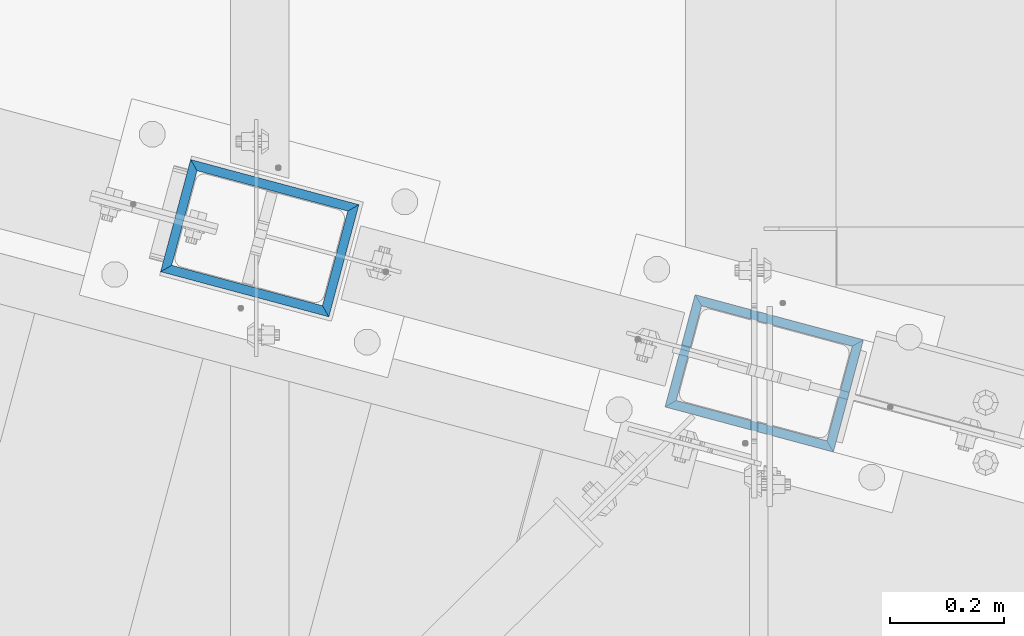
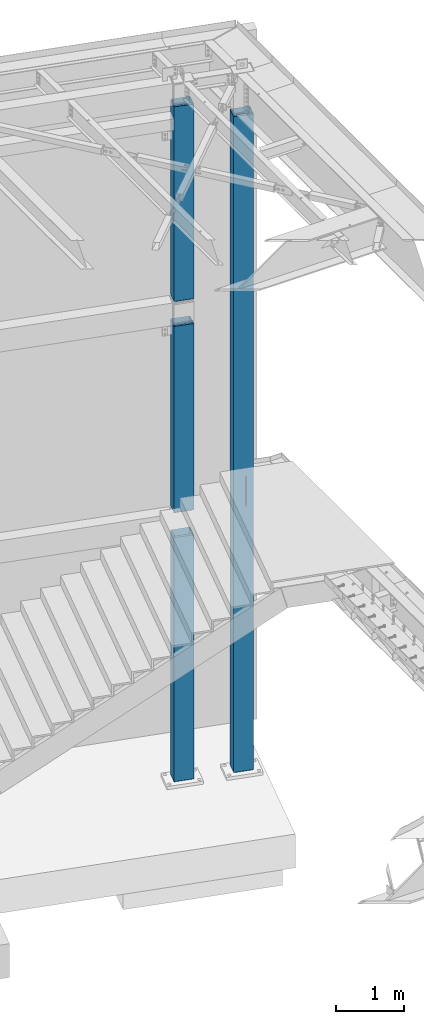
# One storey, part 917 of 1763: 4 columns, 2 elements without a shape of their own.
"""IFC2X3 building model written with IfcOpenShell, lengths in millimetres."""

from ifc_helpers import new_model, si_unit, frame, origin_with_axes, place, context, subcontext, project, spatial, faceted_brep, material, type_object, element, aggregate, save


model = new_model("IFC2X3")

# Units and contexts
model_context = context("Model", 3, precision=1e-05, world=origin_with_axes())
body_context = subcontext(model_context, "Body", "Model", "MODEL_VIEW")
ifc_project = project(units=[si_unit("LENGTHUNIT", "METRE", prefix="MILLI"), si_unit("AREAUNIT", "SQUARE_METRE"), si_unit("VOLUMEUNIT", "CUBIC_METRE"), si_unit("MASSUNIT", "GRAM", prefix="KILO"), si_unit("TIMEUNIT", "SECOND"), si_unit("PLANEANGLEUNIT", "RADIAN"), si_unit("SOLIDANGLEUNIT", "STERADIAN"), si_unit("THERMODYNAMICTEMPERATUREUNIT", "DEGREE_CELSIUS"), si_unit("LUMINOUSINTENSITYUNIT", "LUMEN")], contexts=[model_context])

# Site, building, storey
site_placement = place(None, origin_with_axes())
site = spatial("IfcSite", under=ifc_project, at=site_placement, CompositionType="ELEMENT")
building_placement = place(site_placement, origin_with_axes())
building = spatial("IfcBuilding", under=site, at=building_placement, Name="Undefined", CompositionType="ELEMENT")
storey_placement = place(building_placement, origin_with_axes())
storey = spatial("IfcBuildingStorey", under=building, at=storey_placement, Name="Undefined", CompositionType="ELEMENT", Elevation=0.0)

# Assembly, columns
assembly_1_placement = place(storey_placement, origin_with_axes())
assembly_1 = element("IfcElementAssembly", 1, at=assembly_1_placement, inside=storey, Name="COLUMN", AssemblyPlace="NOTDEFINED", PredefinedType="RIGID_FRAME")
ifc_material = material()
column_type = type_object("IfcColumnType", Name="HSS12X8X5/8", PredefinedType="NOTDEFINED")
column_1_placement = place(assembly_1_placement, frame((-22546.3296171216, 62092.5154188674, 8483.6), z_axis=(-0.965913267114846, 0.258865912030774, 0.0), x_axis=(0.0, 0.0, 1.0)))
column_1 = element("IfcColumn", 2, at=column_1_placement, type_object=column_type, material=ifc_material, Name="COLUMN", ObjectType="HSS12X8X5/8", context=body_context, shape_type="Brep", body=[
    faceted_brep([(22.2250001691827, -101.599999999904, -152.40000000006), (6.35000000000036, -85.7249999999112, -136.525000000045), (6.35000000000036, 85.7250000000859, -136.524999999936), (22.22500016919, 101.600000000093, -152.399999999921), (22.2249997738745, -101.599999773942, 152.400000112088), (6.35000000000036, -85.7250000000786, 136.524999999943), (22.2249996600258, 101.599999999904, 152.40000000006), (6.35000000000036, 85.7249999999112, 136.525000000045), (3549.64999997895, 85.7249999999112, 136.525000000045), (3549.64999997905, -85.7250000000786, 136.524999999943), (3549.64999989041, -85.7249999999112, -136.525000000045), (3549.64999984625, 85.7250000000859, -136.524999999936), (3533.77500004536, 101.599999999904, 152.40000000006), (3533.77499965904, 101.600000000093, -152.399999999921), (3533.77499965725, -101.599999999904, -152.40000000006), (3533.77500004478, -101.599999998667, 152.400000000634)], [[[0, 1, 2, 3]], [[4, 5, 1, 0]], [[6, 7, 5, 4]], [[5, 7, 8, 9]], [[1, 5, 9, 10]], [[2, 1, 10, 11]], [[7, 2, 11, 8]], [[6, 3, 2, 7]], [[3, 6, 12, 13]], [[0, 3, 13, 14]], [[4, 0, 14, 15]], [[6, 4, 15, 12]], [[8, 12, 15, 9]], [[13, 12, 8, 11]], [[14, 13, 11, 10]], [[15, 14, 10, 9]], [[11, 8, 11, 10, 9, 10]]]),
])
column_2_placement = place(assembly_1_placement, frame((-22546.3296174484, 62092.515418955, 4673.6), z_axis=(-0.965913267114846, 0.258865912030774, 0.0), x_axis=(0.0, 0.0, 1.0)))
column_2 = element("IfcColumn", 3, at=column_2_placement, type_object=column_type, material=ifc_material, Name="COLUMN", ObjectType="HSS12X8X5/8", context=body_context, shape_type="Brep", body=[
    faceted_brep([(3397.25, 85.7249999999185, 136.525000000045), (3397.25, 85.7250000000859, -136.524999999936), (3381.37499999995, 101.600000000093, -152.399999999921), (3381.37500000165, 101.599999999904, 152.40000000006), (3397.25, -85.724999999904, -136.525000000045), (3381.37499999999, -101.599999999897, -152.40000000006), (3397.25, -85.7250000001004, 136.524999999914), (3381.37500000178, -101.600000000079, 152.399999999929), (22.2250001691827, -101.599999999904, -152.40000000006), (6.35000000000036, -85.7249999999112, -136.525000000045), (6.35000000000036, 85.7250000000859, -136.524999999936), (22.22500016919, 101.600000000093, -152.399999999921), (22.2249997738745, -101.599999773942, 152.400000112088), (6.35000000000036, -85.7250000000786, 136.524999999943), (22.2249996600258, 101.599999999904, 152.40000000006), (6.35000000000036, 85.7249999999112, 136.525000000045)], [[[0, 1, 2, 3]], [[4, 5, 2, 1]], [[6, 7, 5, 4]], [[8, 9, 10, 11]], [[12, 13, 9, 8]], [[14, 15, 13, 12]], [[13, 15, 0, 6]], [[9, 13, 6, 4]], [[10, 9, 4, 1]], [[15, 10, 1, 0]], [[14, 11, 10, 15]], [[11, 14, 3, 2]], [[8, 11, 2, 5]], [[12, 8, 5, 7]], [[14, 12, 7, 3]], [[0, 3, 7, 6]]]),
])

# Assembly, column
assembly_2_placement = place(storey_placement, origin_with_axes())
assembly_2 = element("IfcElementAssembly", 4, at=assembly_2_placement, inside=storey, Name="COLUMN", AssemblyPlace="NOTDEFINED", PredefinedType="RIGID_FRAME")
column_3_placement = place(assembly_2_placement, frame((-21663.6796174484, 61856.0100642785, -304.799999999999), z_axis=(-0.965913267114846, 0.258865912030774, 0.0), x_axis=(0.0, 0.0, 1.0)))
column_3 = element("IfcColumn", 5, at=column_3_placement, type_object=column_type, material=ifc_material, Name="COLUMN", ObjectType="HSS12X8X5/8", context=body_context, shape_type="Brep", body=[
    faceted_brep([(4730.14575203769, -3.06557584600523, 152.399999999863), (4730.14575205626, -3.065422807922, 136.524999999987), (4728.42500623508, -5.64058646713966, 136.52499999998), (4728.42500621652, -5.64073950522288, 152.399999999856), (4725.84974835626, -7.36119127653365, 136.52499999998), (4725.8497483377, -7.36134431461687, 152.399999999849), (4722.812065083, -7.96527271442756, 136.52499999998), (4722.81206506443, -7.96542575251078, 152.399999999849), (4421.18707316746, -7.94875237207452, 136.524999999987), (4421.18707314889, -7.94890541016503, 152.399999999849), (4418.1496551997, -7.34442067197961, 136.52499999998), (4418.14965518113, -7.34457371005556, 152.399999999849), (4415.57469148241, -5.6237560999507, 136.524999999987), (4415.57469146384, -5.62390913802665, 152.399999999849), (4413.85417037976, -3.0486965180171, 136.524999999987), (4413.85417036119, -3.04884955610032, 152.399999999856), (4413.25000791334, -0.0112448839063291, 136.524999999987), (4413.25000789478, -0.0113979219822795, 152.399999999863), (4413.85421627596, 3.02673541568947, 136.524999999994), (4413.8542162574, 3.02658237760625, 152.399999999863), (4415.57485048596, 5.60184320072585, 136.524999999994), (4415.57485046739, 5.60169016264263, 152.39999999987), (4418.14995989435, 7.32247498109064, 136.524999999994), (4418.14995987578, 7.32232194301469, 152.39999999987), (4421.18750790333, 7.92668047730695, 136.524999999994), (4421.18750788477, 7.92652743920917, 152.39999999987), (4722.81249981823, 7.92668087384664, 136.524999999994), (4722.81249979967, 7.92652783575613, 152.399999999878), (4725.85004954067, 7.32247467654815, 136.524999999994), (4725.8500495221, 7.32232163846493, 152.399999999878), (4728.42515986212, 5.60184099161415, 136.524999999994), (4728.42515984355, 5.6016879535382, 152.39999999987), (4730.1457935857, 3.02673069592856, 136.524999999987), (4730.14579356713, 3.02657765784534, 152.39999999987), (4730.74999982888, -0.0277726170024835, 136.524999999987), (4730.74999981032, -0.0279256550857099, 152.399999999863), (4730.14575237562, -3.06279055288906, -136.524999999994), (4730.14575239419, -3.06263751480583, -152.399999999994), (4728.42500657301, -5.63780117402348, -152.399999999994), (4728.42500655445, -5.63795421210671, -136.524999999994), (4725.84974869419, -7.35840598341019, -152.399999999994), (4725.84974867563, -7.35855902149342, -136.524999999994), (4722.81206542093, -7.96248742131138, -152.399999999994), (4722.81206540236, -7.96264045940188, -136.524999999994), (4421.18707350539, -7.94596707896562, -152.399999999994), (4421.18707348682, -7.94612011704157, -136.524999999994), (4418.14965553763, -7.34163537886343, -152.399999999994), (4418.14965551906, -7.34178841694666, -136.524999999994), (4415.57469182034, -5.62097080682724, -152.399999999994), (4415.57469180177, -5.62112384491775, -136.524999999994), (4413.85417071769, -3.04591122489364, -152.399999999994), (4413.85417069912, -3.04606426297687, -136.524999999994), (4413.25000825127, -0.00845959079015302, -152.399999999994), (4413.2500082327, -0.00861262886610348, -136.524999999994), (4413.85421661389, 3.02952070880565, -152.399999999994), (4413.85421659533, 3.0293676707297, -136.524999999994), (4415.57485082389, 5.60462849384203, -152.399999999987), (4415.57485080532, 5.6044754557588, -136.524999999994), (4418.14996023228, 7.32526027420681, -152.399999999987), (4418.14996021371, 7.32510723612359, -136.524999999987), (4421.18750824126, 7.92946577042312, -152.399999999987), (4421.1875082227, 7.92931273233989, -136.52499999998), (4722.81250015616, 7.92946616695554, -152.399999999987), (4722.8125001376, 7.92931312887231, -136.524999999987), (4725.8500498786, 7.32525996965705, -152.399999999987), (4725.85004986003, 7.32510693157383, -136.524999999987), (4728.42516020005, 5.60462628473033, -152.399999999987), (4728.42516018148, 5.6044732466471, -136.524999999987), (4730.14579392362, 3.02951598903746, -152.399999999987), (4730.14579390506, 3.02936295096151, -136.524999999994), (4730.75000016681, -0.0249873238935834, -152.399999999994), (4730.75000014825, -0.0251403619695338, -136.524999999994), (11979.2750000017, -101.600000000086, 152.399999999921), (11979.2750000016, 101.599999999904, 152.40000000006), (146.049999998875, 101.599999999904, 152.40000000006), (146.04999999961, -101.599999999642, 152.399999999507), (133.349999999999, 88.9000000002707, 139.700000000703), (133.349999999999, -88.9000000004235, 139.700000000703), (133.349999999999, -88.8999999998487, -139.700000000019), (146.050000000045, -101.599999999897, -152.40000000006), (133.349999999999, -85.724999999904, -136.525000000045), (133.349999999999, -85.7250000000786, 136.524999999936), (11995.15, -85.7250000000859, 136.524999999907), (11995.15, -85.724999999904, -136.525000000045), (5465.4901036744, -85.7249999999694, -28.1766004742894), (5463.43001544033, -85.7249999999694, -26.7515170872939), (5460.9999756813, -85.7249999999767, -26.2510943498201), (4927.59999990463, -85.7249999999767, -26.2510943498201), (4925.16996014561, -85.7249999999694, -26.7515170872939), (4923.10987191153, -85.7249999999694, -28.1766004742894), (4921.73336496129, -85.7249999999767, -30.3093884835398), (4921.25, -85.7249999999694, -32.8251834744078), (4921.73336496129, -85.7249999999694, -35.3409784652758), (4923.10987191153, -85.7249999999622, -37.4737664745189), (4925.16996014561, -85.7249999999694, -38.8988498615145), (4927.59999990463, -85.7249999999622, -39.3992725989956), (5460.9999756813, -85.7249999999622, -39.3992725989956), (5463.43001544033, -85.7249999999694, -38.8988498615145), (5465.4901036744, -85.7249999999622, -37.4737664745189), (5466.86661062464, -85.7249999999694, -35.3409784652758), (5467.34997558594, -85.7249999999694, -32.8251834744078), (5466.86661062464, -85.7249999999767, -30.3093884835398), (5465.4901036744, -101.599999999962, -41.7282854809382), (5466.86661062464, -101.599999999962, -39.5954974716951), (5463.43001544033, -101.599999999955, -43.1533688679338), (5460.9999756813, -101.599999999962, -43.6537916054076), (4927.59999990463, -101.599999999962, -43.6537916054076), (4925.16996014561, -101.599999999955, -43.1533688679338), (4923.10987191153, -101.599999999962, -41.7282854809382), (4921.73336496129, -101.599999999962, -39.5954974716951), (4921.25, -101.599999999962, -37.0797024808198), (4921.73336496129, -101.599999999962, -34.5639074899518), (4923.10987191153, -101.599999999962, -32.4311194807015), (4925.16996014561, -101.599999999969, -31.0060360937132), (4927.59999990463, -101.599999999969, -30.5056133562321), (5460.9999756813, -101.599999999969, -30.5056133562321), (5463.43001544033, -101.599999999969, -31.0060360937132), (5465.4901036744, -101.599999999962, -32.4311194807015), (5466.86661062464, -101.599999999962, -34.5639074899518), (5467.34997558594, -101.599999999962, -37.0797024808198), (11979.275, -101.599999999897, -152.40000000006), (11995.15, 85.7249999999185, 136.525000000045), (133.349999999999, 85.7249999999185, 136.525000000045), (133.349999999999, 85.7250000000931, -136.524999999936), (11995.15, 85.7250000000931, -136.524999999936), (5465.49012808847, 85.7250000000058, 8.47503879474971), (5463.43003985439, 85.7249999999985, 7.04995540775417), (5461.00000009537, 85.7250000000058, 6.54953267028031), (4927.60002431869, 85.7250000000058, 6.54953267028031), (4925.16998455967, 85.7249999999985, 7.04995540775417), (4923.10989632559, 85.7250000000058, 8.47503879474971), (4921.73338937535, 85.7249999999985, 10.6078268039928), (4921.25002441406, 85.7249999999913, 13.1236217948681), (4921.73338937535, 85.7249999999913, 15.6394167857361), (4923.10989632559, 85.7249999999913, 17.7722047949865), (4925.16998455967, 85.7249999999913, 19.1972881819747), (4927.60002431869, 85.7249999999913, 19.6977109194486), (5461.00000009537, 85.7249999999913, 19.6977109194486), (5463.43003985439, 85.7249999999913, 19.1972881819747), (5465.49012808847, 85.7249999999913, 17.7722047949865), (5466.8666350387, 85.7249999999913, 15.6394167857361), (5467.35, 85.7249999999913, 13.1236217948681), (5466.8666350387, 85.7249999999985, 10.6078268039928), (5466.8666350387, 101.599999999991, 14.8623458104048), (5467.35, 101.599999999984, 17.3781408012801), (5465.49012808847, 101.599999999991, 12.729557801169), (5463.43003985439, 101.599999999999, 11.3044744141735), (5461.00000009537, 101.599999999991, 10.8040516766923), (4927.60002431869, 101.599999999991, 10.8040516766923), (4925.16998455967, 101.599999999999, 11.3044744141735), (4923.10989632559, 101.599999999991, 12.729557801169), (4921.73338937535, 101.599999999991, 14.8623458104048), (4921.25002441406, 101.599999999984, 17.3781408012801), (4921.73338937535, 101.599999999991, 19.8939357921481), (4923.10989632559, 101.599999999984, 22.0267238013985), (4925.16998455967, 101.599999999991, 23.4518071883867), (4927.60002431869, 101.599999999984, 23.9522299258679), (5461.00000009537, 101.599999999984, 23.9522299258679), (5463.43003985439, 101.599999999991, 23.4518071883867), (5465.49012808847, 101.599999999984, 22.0267238013985), (5466.8666350387, 101.599999999991, 19.8939357921481), (11979.275, 101.6000000001, -152.399999999921), (146.050000000008, 101.6000000001, -152.399999999921), (133.349999999999, 88.9000000001033, -139.69999999991)], [[[0, 1, 2, 3]], [[3, 2, 4, 5]], [[5, 4, 6, 7]], [[7, 6, 8, 9]], [[9, 8, 10, 11]], [[11, 10, 12, 13]], [[13, 12, 14, 15]], [[15, 14, 16, 17]], [[17, 16, 18, 19]], [[19, 18, 20, 21]], [[21, 20, 22, 23]], [[23, 22, 24, 25]], [[25, 24, 26, 27]], [[27, 26, 28, 29]], [[29, 28, 30, 31]], [[31, 30, 32, 33]], [[33, 32, 34, 35]], [[35, 34, 1, 0]], [[36, 37, 38, 39]], [[39, 38, 40, 41]], [[41, 40, 42, 43]], [[43, 42, 44, 45]], [[45, 44, 46, 47]], [[47, 46, 48, 49]], [[49, 48, 50, 51]], [[51, 50, 52, 53]], [[53, 52, 54, 55]], [[55, 54, 56, 57]], [[57, 56, 58, 59]], [[59, 58, 60, 61]], [[61, 60, 62, 63]], [[63, 62, 64, 65]], [[65, 64, 66, 67]], [[67, 66, 68, 69]], [[69, 68, 70, 71]], [[71, 70, 37, 36]], [[72, 73, 74, 75], [3, 5, 7, 9, 11, 13, 15, 17, 19, 21, 23, 25, 27, 29, 31, 33, 35, 0]], [[74, 76, 77, 75]], [[75, 77, 78, 79]], [[80, 81, 82, 83], [84, 85, 86, 87, 88, 89, 90, 91, 92, 93, 94, 95, 96, 97, 98, 99, 100, 101]], [[98, 102, 103, 99]], [[97, 104, 102, 98]], [[96, 105, 104, 97]], [[95, 106, 105, 96]], [[94, 107, 106, 95]], [[93, 108, 107, 94]], [[92, 109, 108, 93]], [[91, 110, 109, 92]], [[90, 111, 110, 91]], [[89, 112, 111, 90]], [[88, 113, 112, 89]], [[87, 114, 113, 88]], [[86, 115, 114, 87]], [[85, 116, 115, 86]], [[84, 117, 116, 85]], [[101, 118, 117, 84]], [[100, 119, 118, 101]], [[99, 103, 119, 100]], [[120, 72, 75, 79], [102, 104, 105, 106, 107, 108, 109, 110, 111, 112, 113, 114, 115, 116, 117, 118, 119, 103]], [[82, 72, 120, 83]], [[121, 73, 72, 82]], [[81, 122, 121, 82], [30, 28, 26, 24, 22, 20, 18, 16, 14, 12, 10, 8, 6, 4, 2, 1, 34, 32]], [[122, 123, 124, 121], [125, 126, 127, 128, 129, 130, 131, 132, 133, 134, 135, 136, 137, 138, 139, 140, 141, 142]], [[143, 142, 141, 144]], [[145, 125, 142, 143]], [[146, 126, 125, 145]], [[147, 127, 126, 146]], [[148, 128, 127, 147]], [[149, 129, 128, 148]], [[150, 130, 129, 149]], [[151, 131, 130, 150]], [[152, 132, 131, 151]], [[153, 133, 132, 152]], [[154, 134, 133, 153]], [[155, 135, 134, 154]], [[156, 136, 135, 155]], [[157, 137, 136, 156]], [[158, 138, 137, 157]], [[159, 139, 138, 158]], [[160, 140, 139, 159]], [[144, 141, 140, 160]], [[73, 161, 162, 74], [159, 158, 157, 156, 155, 154, 153, 152, 151, 150, 149, 148, 147, 146, 145, 143, 144, 160]], [[121, 124, 161, 73]], [[83, 120, 161, 124]], [[123, 80, 83, 124], [39, 41, 43, 45, 47, 49, 51, 53, 55, 57, 59, 61, 63, 65, 67, 69, 71, 36]], [[76, 163, 78, 77], [122, 81, 80, 123]], [[74, 162, 163, 76]], [[79, 78, 163, 162]], [[161, 120, 79, 162], [66, 64, 62, 60, 58, 56, 54, 52, 50, 48, 46, 44, 42, 40, 38, 37, 70, 68]]]),
])
aggregate(assembly_2, [column_3])

# Column
column_4_placement = place(assembly_1_placement, frame((-22546.3296174145, 62092.5154189459, -304.8), z_axis=(-0.965913267114846, 0.258865912030774, 0.0), x_axis=(0.0, 0.0, 1.0)))
column_4 = element("IfcColumn", 6, at=column_4_placement, type_object=column_type, material=ifc_material, Name="COLUMN", ObjectType="HSS12X8X5/8", context=body_context, shape_type="Brep", body=[
    faceted_brep([(146.049999998875, 101.599999999904, 152.40000000006), (146.050000000008, 101.6000000001, -152.399999999921), (133.349999999999, 88.9000000001033, -139.69999999991), (133.349999999999, 88.9000000002707, 139.700000000703), (146.050000000045, -101.599999999897, -152.40000000006), (133.349999999999, -88.8999999998487, -139.700000000019), (146.04999999961, -101.599999999642, 152.399999999507), (133.349999999999, -88.9000000004235, 139.700000000703), (133.349999999999, 85.7249999999185, 136.525000000045), (133.349999999999, 85.7250000000931, -136.524999999936), (4565.65, 85.7250000000786, -136.524999999936), (4565.65, 85.7249999999112, 136.525000000045), (133.349999999999, -85.7250000000786, 136.524999999936), (4565.65000001169, -85.724999988437, 136.525000023285), (133.349999999999, -85.724999999904, -136.525000000045), (4565.65, -85.7249999999112, -136.525000000045), (4549.77500003684, -101.600000000093, 152.399999999921), (4549.77499998247, -101.599999999897, -152.40000000006), (4549.77500003671, 101.599999999904, 152.400000000052), (4549.7749999824, 101.600000000093, -152.399999999929)], [[[0, 1, 2, 3]], [[4, 5, 2, 1]], [[6, 7, 5, 4]], [[8, 9, 10, 11]], [[12, 8, 11, 13]], [[14, 12, 13, 15]], [[13, 16, 17, 15]], [[11, 18, 16, 13]], [[16, 18, 0, 6]], [[17, 16, 6, 4]], [[19, 17, 4, 1]], [[18, 19, 1, 0]], [[11, 10, 19, 18]], [[15, 17, 19, 10]], [[9, 14, 15, 10]], [[3, 2, 5, 7], [8, 12, 14, 9]], [[0, 3, 7, 6]]]),
])

aggregate(assembly_1, [column_1, column_2, column_4])

save(model, "model.ifc")
